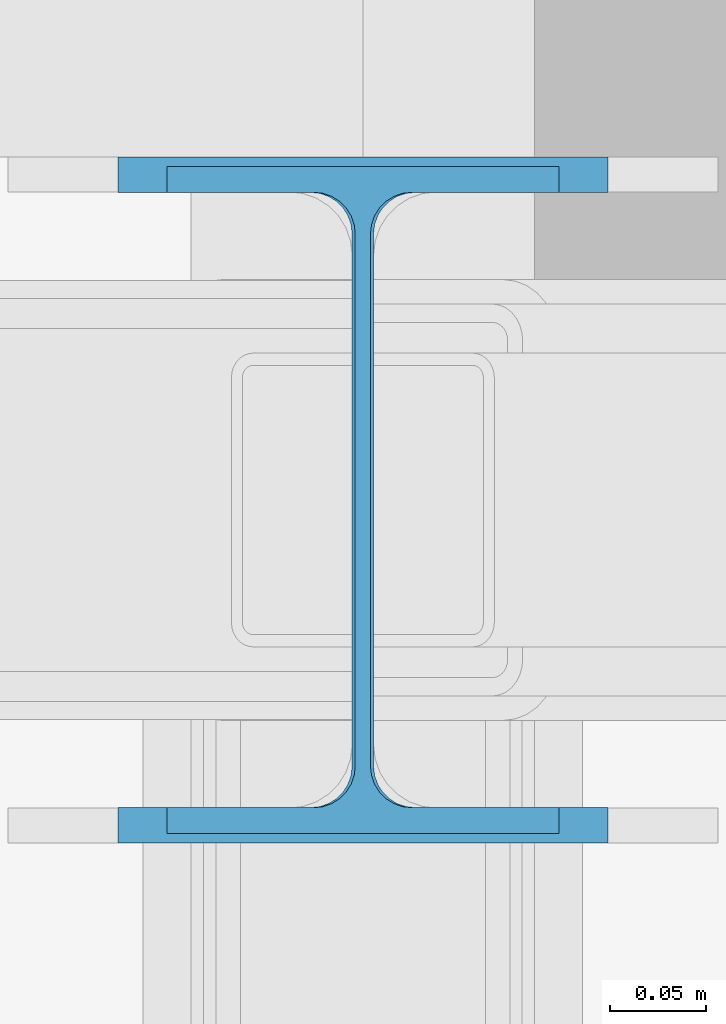
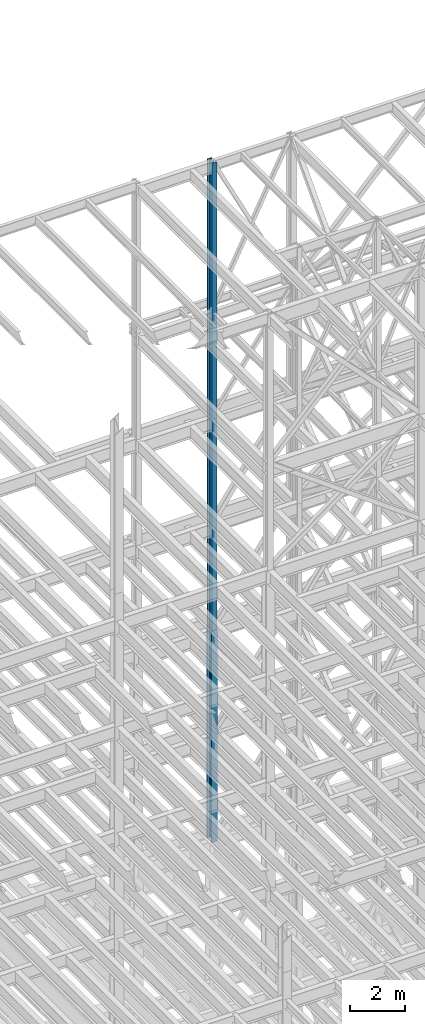
# One storey, part 42 of 150: 3 columns.
"""IFC2X3 building model written with IfcOpenShell, lengths in millimetres."""

from ifc_helpers import new_model, si_unit, frame, origin_with_axes, origin_2d_with_axis, place, context, subcontext, project, spatial, i_section, extrude, material, type_object, element, save


model = new_model("IFC2X3")

# Units and contexts
model_context = context("Model", 3, precision=1e-05, world=origin_with_axes())
body_context = subcontext(model_context, "Body", "Model", "MODEL_VIEW")
ifc_project = project(units=[si_unit("LENGTHUNIT", "METRE", prefix="MILLI"), si_unit("AREAUNIT", "SQUARE_METRE"), si_unit("VOLUMEUNIT", "CUBIC_METRE"), si_unit("MASSUNIT", "GRAM", prefix="KILO"), si_unit("TIMEUNIT", "SECOND"), si_unit("PLANEANGLEUNIT", "RADIAN"), si_unit("SOLIDANGLEUNIT", "STERADIAN"), si_unit("THERMODYNAMICTEMPERATUREUNIT", "DEGREE_CELSIUS"), si_unit("LUMINOUSINTENSITYUNIT", "LUMEN")], contexts=[model_context])

# Site, building, storey
site_placement = place(None, origin_with_axes())
site = spatial("IfcSite", under=ifc_project, at=site_placement, CompositionType="ELEMENT")
building_placement = place(site_placement, origin_with_axes())
building = spatial("IfcBuilding", under=site, at=building_placement, Name="Undefined", CompositionType="ELEMENT")
storey_placement = place(building_placement, origin_with_axes())
storey = spatial("IfcBuildingStorey", under=building, at=storey_placement, Name="Undefined", CompositionType="ELEMENT", Elevation=0.0)

# Columns
ifc_material = material(Name="STEEL/A992")
column_type_1 = type_object("IfcColumnType", Name="W14X43", PredefinedType="NOTDEFINED")
column_1_placement = place(storey_placement, frame((53238.4, 31877.0, 54483.0), z_axis=(0.0, 0.0, 1.0), x_axis=(1.0, 0.0, 0.0)))
element("IfcColumn", 1, at=column_1_placement, inside=storey, type_object=column_type_1, material=ifc_material, Name="COLUMN", ObjectType="W14X43", context=body_context, shape_type="SweptSolid", body=[
    extrude(i_section(OverallWidth=203.2, OverallDepth=346.075, WebThickness=7.9375, FlangeThickness=13.462, FilletRadius=21.4629, at=origin_2d_with_axis()), frame((0.0, 0.0, 11429.998857), z_axis=(0.0, 0.0, -1.0), x_axis=(-1.0, 0.0, 0.0)), (0.0, 0.0, 1.0), 11429.998857),
])
column_2_placement = place(storey_placement, frame((53238.4, 31877.0, 45034.2), z_axis=(0.0, 0.0, 1.0), x_axis=(1.0, 0.0, 0.0)))
element("IfcColumn", 2, at=column_2_placement, inside=storey, type_object=column_type_1, material=ifc_material, Name="COLUMN", ObjectType="W14X43", context=body_context, shape_type="SweptSolid", body=[
    extrude(i_section(OverallWidth=203.2, OverallDepth=346.075, WebThickness=7.9375, FlangeThickness=13.462, FilletRadius=21.4629, at=origin_2d_with_axis()), frame((0.0, 0.0, 9448.8), z_axis=(0.0, 0.0, -1.0), x_axis=(-1.0, 0.0, 0.0)), (0.0, 0.0, 1.0), 9448.8),
])
column_type_2 = type_object("IfcColumnType", Name="W14X68", PredefinedType="NOTDEFINED")
column_3_placement = place(storey_placement, frame((53238.4, 31877.0, 35585.4), z_axis=(0.0, 0.0, 1.0), x_axis=(1.0, 0.0, 0.0)))
element("IfcColumn", 3, at=column_3_placement, inside=storey, type_object=column_type_2, material=ifc_material, Name="COLUMN", ObjectType="W14X68", context=body_context, shape_type="SweptSolid", body=[
    extrude(i_section(OverallWidth=254.0, OverallDepth=355.6, WebThickness=11.1125, FlangeThickness=18.288, FilletRadius=21.3994, at=origin_2d_with_axis()), frame((0.0, 0.0, 9448.8), z_axis=(0.0, 0.0, -1.0), x_axis=(-1.0, 0.0, 0.0)), (0.0, 0.0, 1.0), 9448.8),
])

save(model, "model.ifc")
